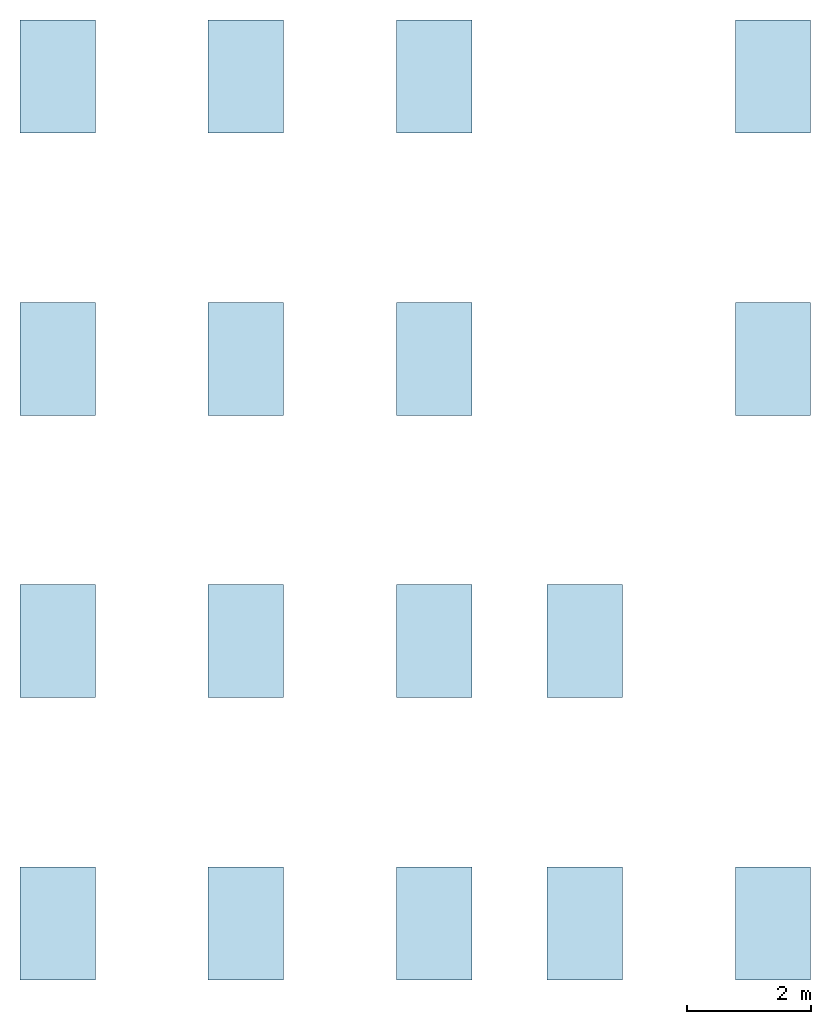
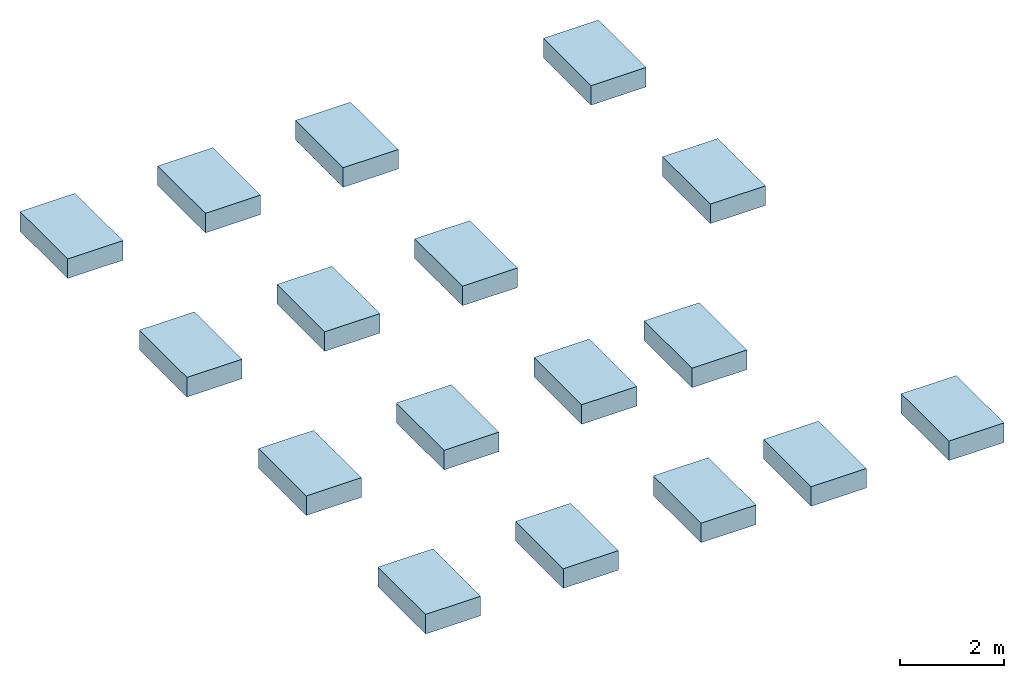
# One storey: 17 slabs.
"""IFC2X3 building model written with IfcOpenShell, lengths in feet."""

from ifc_helpers import new_model, entity, si_unit, converted_unit, derived_unit, direction, frame, frame_2d, origin, origin_2d_with_axis, place, context, subcontext, project, spatial, rectangle, extrude, material, type_object, element, save


model = new_model("IFC2X3")

# Units and contexts
model_context = context("Model", 3, precision=0.0001, world=origin(), true_north=direction((6.123031769111886e-17, 1.0)))
body_context = subcontext(model_context, "Body", "Model", "MODEL_VIEW")
ifc_project = project(units=[converted_unit("LENGTHUNIT", "FOOT", entity("IfcLengthMeasure", 0.3048), si_unit("LENGTHUNIT", "METRE"), dimensions=[1, 0, 0, 0, 0, 0, 0]), converted_unit("AREAUNIT", "SQUARE FOOT", entity("IfcAreaMeasure", 0.09290304), si_unit("AREAUNIT", "SQUARE_METRE"), dimensions=[2, 0, 0, 0, 0, 0, 0]), converted_unit("VOLUMEUNIT", "CUBIC FOOT", entity("IfcVolumeMeasure", 0.028316846592000004), si_unit("VOLUMEUNIT", "CUBIC_METRE"), dimensions=[3, 0, 0, 0, 0, 0, 0]), converted_unit("PLANEANGLEUNIT", "DEGREE", entity("IfcPlaneAngleMeasure", 0.017453292519943278), si_unit("PLANEANGLEUNIT", "RADIAN"), dimensions=[0, 0, 0, 0, 0, 0, 0]), si_unit("MASSUNIT", "GRAM", prefix="KILO"), derived_unit("MASSDENSITYUNIT", [(si_unit("MASSUNIT", "GRAM", prefix="KILO"), 1), (si_unit("LENGTHUNIT", "METRE"), -3)]), derived_unit("IONCONCENTRATIONUNIT", [(si_unit("MASSUNIT", "GRAM", prefix="KILO"), 1), (si_unit("LENGTHUNIT", "METRE"), -3)]), derived_unit("MOMENTOFINERTIAUNIT", [(si_unit("LENGTHUNIT", "METRE"), 4)]), si_unit("TIMEUNIT", "SECOND"), si_unit("FREQUENCYUNIT", "HERTZ"), si_unit("THERMODYNAMICTEMPERATUREUNIT", "DEGREE_CELSIUS"), derived_unit("THERMALTRANSMITTANCEUNIT", [(si_unit("MASSUNIT", "GRAM", prefix="KILO"), 1), (si_unit("THERMODYNAMICTEMPERATUREUNIT", "KELVIN"), -1), (si_unit("TIMEUNIT", "SECOND"), -3)]), derived_unit("THERMALCONDUCTANCEUNIT", [(si_unit("MASSUNIT", "GRAM", prefix="KILO"), 1), (si_unit("THERMODYNAMICTEMPERATUREUNIT", "KELVIN"), -1), (si_unit("TIMEUNIT", "SECOND"), -3), (si_unit("LENGTHUNIT", "METRE"), 1)]), derived_unit("VOLUMETRICFLOWRATEUNIT", [(si_unit("LENGTHUNIT", "METRE"), 3), (si_unit("TIMEUNIT", "SECOND"), -1)]), derived_unit("MASSFLOWRATEUNIT", [(si_unit("MASSUNIT", "GRAM", prefix="KILO"), 1), (si_unit("TIMEUNIT", "SECOND"), -1)]), derived_unit("ROTATIONALFREQUENCYUNIT", [(si_unit("TIMEUNIT", "SECOND"), -1)]), si_unit("ELECTRICCURRENTUNIT", "AMPERE"), si_unit("ELECTRICVOLTAGEUNIT", "VOLT"), si_unit("POWERUNIT", "WATT"), converted_unit("FORCEUNIT", "KIP", entity("IfcForceMeasure", 2.088543423315013e-05), si_unit("FORCEUNIT", "NEWTON"), dimensions=[1, 1, -2, 0, 0, 0, 0]), si_unit("ILLUMINANCEUNIT", "LUX"), si_unit("LUMINOUSFLUXUNIT", "LUMEN"), si_unit("LUMINOUSINTENSITYUNIT", "CANDELA"), si_unit("ENERGYUNIT", "JOULE"), derived_unit("USERDEFINED", [(si_unit("MASSUNIT", "GRAM", prefix="KILO"), -1), (si_unit("LENGTHUNIT", "METRE"), -2), (si_unit("TIMEUNIT", "SECOND"), 3), (si_unit("LUMINOUSFLUXUNIT", "LUMEN"), 1)]), derived_unit("USERDEFINED", [(si_unit("MASSUNIT", "GRAM", prefix="KILO"), 1), (si_unit("TIMEUNIT", "SECOND"), -3), (si_unit("LENGTHUNIT", "METRE"), 3), (si_unit("ELECTRICCURRENTUNIT", "AMPERE"), -2)]), derived_unit("SOUNDPOWERUNIT", [(si_unit("MASSUNIT", "GRAM", prefix="KILO"), 1), (si_unit("TIMEUNIT", "SECOND"), -3), (si_unit("LENGTHUNIT", "METRE"), 2)]), derived_unit("SOUNDPRESSUREUNIT", [(si_unit("MASSUNIT", "GRAM", prefix="KILO"), 1), (si_unit("LENGTHUNIT", "METRE"), -1), (si_unit("TIMEUNIT", "SECOND"), -2)]), derived_unit("LINEARVELOCITYUNIT", [(si_unit("LENGTHUNIT", "METRE"), 1), (si_unit("TIMEUNIT", "SECOND"), -1)]), si_unit("PRESSUREUNIT", "PASCAL"), derived_unit("USERDEFINED", [(si_unit("MASSUNIT", "GRAM", prefix="KILO"), 1), (si_unit("LENGTHUNIT", "METRE"), -2), (si_unit("TIMEUNIT", "SECOND"), -2)]), derived_unit("LINEARFORCEUNIT", [(si_unit("MASSUNIT", "GRAM", prefix="KILO"), 1), (si_unit("TIMEUNIT", "SECOND"), -2)]), derived_unit("PLANARFORCEUNIT", [(si_unit("MASSUNIT", "GRAM", prefix="KILO"), 1), (si_unit("LENGTHUNIT", "METRE"), -1), (si_unit("TIMEUNIT", "SECOND"), -2)]), derived_unit("SPECIFICHEATCAPACITYUNIT", [(si_unit("THERMODYNAMICTEMPERATUREUNIT", "KELVIN"), -1), (si_unit("LENGTHUNIT", "METRE"), 2), (si_unit("TIMEUNIT", "SECOND"), -2)]), derived_unit("HEATFLUXDENSITYUNIT", [(si_unit("MASSUNIT", "GRAM", prefix="KILO"), 1), (si_unit("TIMEUNIT", "SECOND"), -3)]), derived_unit("HEATINGVALUEUNIT", [(si_unit("LENGTHUNIT", "METRE"), 2), (si_unit("TIMEUNIT", "SECOND"), -2)]), derived_unit("VAPORPERMEABILITYUNIT", [(si_unit("LENGTHUNIT", "METRE"), -1), (si_unit("TIMEUNIT", "SECOND"), 1)]), derived_unit("DYNAMICVISCOSITYUNIT", [(si_unit("MASSUNIT", "GRAM", prefix="KILO"), 1), (si_unit("TIMEUNIT", "SECOND"), -1), (si_unit("LENGTHUNIT", "METRE"), -1)]), derived_unit("THERMALEXPANSIONCOEFFICIENTUNIT", [(si_unit("THERMODYNAMICTEMPERATUREUNIT", "KELVIN"), -1)]), derived_unit("MODULUSOFELASTICITYUNIT", [(si_unit("MASSUNIT", "GRAM", prefix="KILO"), 1), (si_unit("LENGTHUNIT", "METRE"), -1), (si_unit("TIMEUNIT", "SECOND"), -2)]), derived_unit("ISOTHERMALMOISTURECAPACITYUNIT", [(si_unit("LENGTHUNIT", "METRE"), 3), (si_unit("MASSUNIT", "GRAM", prefix="KILO"), -1)]), derived_unit("MOISTUREDIFFUSIVITYUNIT", [(si_unit("TIMEUNIT", "SECOND"), -1), (si_unit("LENGTHUNIT", "METRE"), 2)]), derived_unit("MASSPERLENGTHUNIT", [(si_unit("MASSUNIT", "GRAM", prefix="KILO"), 1), (si_unit("LENGTHUNIT", "METRE"), -1)]), derived_unit("THERMALRESISTANCEUNIT", [(si_unit("MASSUNIT", "GRAM", prefix="KILO"), -1), (si_unit("TIMEUNIT", "SECOND"), 3), (si_unit("THERMODYNAMICTEMPERATUREUNIT", "KELVIN"), 1)]), derived_unit("ACCELERATIONUNIT", [(si_unit("LENGTHUNIT", "METRE"), 1), (si_unit("TIMEUNIT", "SECOND"), -2)]), derived_unit("ANGULARVELOCITYUNIT", [(si_unit("TIMEUNIT", "SECOND"), -1), (si_unit("PLANEANGLEUNIT", "RADIAN"), 1)]), derived_unit("LINEARSTIFFNESSUNIT", [(si_unit("MASSUNIT", "GRAM", prefix="KILO"), 1), (si_unit("TIMEUNIT", "SECOND"), -2)]), derived_unit("WARPINGCONSTANTUNIT", [(si_unit("LENGTHUNIT", "METRE"), 6)]), derived_unit("LINEARMOMENTUNIT", [(si_unit("MASSUNIT", "GRAM", prefix="KILO"), 1), (si_unit("LENGTHUNIT", "METRE"), 1), (si_unit("TIMEUNIT", "SECOND"), -2)]), derived_unit("TORQUEUNIT", [(si_unit("MASSUNIT", "GRAM", prefix="KILO"), 1), (si_unit("LENGTHUNIT", "METRE"), 2), (si_unit("TIMEUNIT", "SECOND"), -2)])], contexts=[model_context])

# Site, building, storey
site_placement = place(None, origin())
site = spatial("IfcSite", under=ifc_project, at=site_placement, CompositionType="ELEMENT")
building_placement = place(site_placement, origin())
building = spatial("IfcBuilding", under=site, at=building_placement, CompositionType="ELEMENT")
storey_placement = place(building_placement, frame((0.0, 0.0, -1.5)))
storey = spatial("IfcBuildingStorey", under=building, at=storey_placement, CompositionType="ELEMENT", Elevation=-1.5)

# Slabs
ifc_material = material(Name="Concrete, Cast-in-Place gray")
slab_type = type_object("IfcSlabType", PredefinedType="BASESLAB", material=ifc_material)
slab_1_placement = place(storey_placement, origin())
element("IfcSlab", 1, at=slab_1_placement, inside=storey, type_object=slab_type, PredefinedType="BASESLAB", context=body_context, shape_type="SweptSolid", body=[
    extrude(rectangle(XDim=3.9999999999999982, YDim=6.0, at=origin_2d_with_axis()), frame((9.874478019162163, -49.84124484724893, -1.5), z_axis=(0.0, 0.0, 1.0), x_axis=(-1.0, 0.0, 0.0)), (0.0, 0.0, 1.0), 1.5),
])
slab_2_placement = place(storey_placement, origin())
element("IfcSlab", 2, at=slab_2_placement, inside=storey, type_object=slab_type, PredefinedType="BASESLAB", context=body_context, shape_type="SweptSolid", body=[
    extrude(rectangle(XDim=4.0, YDim=6.0, at=frame_2d((-1.7763568394002505e-15, -7.105427357601002e-15), x_axis=(1.0, 0.0))), frame((29.874478019162154, -49.841244847249, -1.5), z_axis=(0.0, 0.0, 1.0), x_axis=(-1.0, 0.0, 0.0)), (0.0, 0.0, 1.0), 1.5),
])
slab_3_placement = place(storey_placement, origin())
element("IfcSlab", 3, at=slab_3_placement, inside=storey, type_object=slab_type, PredefinedType="BASESLAB", context=body_context, shape_type="SweptSolid", body=[
    extrude(rectangle(XDim=4.0, YDim=6.0, at=frame_2d((3.552713678800501e-15, 7.105427357601002e-15), x_axis=(1.0, 0.0))), frame((37.87447801916216, -49.841244847249015, -1.5), z_axis=(0.0, 0.0, 1.0), x_axis=(-1.0, 0.0, 0.0)), (0.0, 0.0, 1.0), 1.5),
])
slab_4_placement = place(storey_placement, origin())
element("IfcSlab", 4, at=slab_4_placement, inside=storey, type_object=slab_type, PredefinedType="BASESLAB", context=body_context, shape_type="SweptSolid", body=[
    extrude(rectangle(XDim=4.0, YDim=6.0, at=frame_2d((3.552713678800501e-15, 0.0), x_axis=(1.0, 0.0))), frame((47.87447801916217, -49.84124484724906, -1.5), z_axis=(0.0, 0.0, 1.0), x_axis=(-1.0, 0.0, 0.0)), (0.0, 0.0, 1.0), 1.5),
])
slab_5_placement = place(storey_placement, origin())
element("IfcSlab", 5, at=slab_5_placement, inside=storey, type_object=slab_type, PredefinedType="BASESLAB", context=body_context, shape_type="SweptSolid", body=[
    extrude(rectangle(XDim=4.0, YDim=6.0, at=frame_2d((1.7763568394002505e-15, 7.105427357601002e-15), x_axis=(1.0, 0.0))), frame((19.87447801916216, -49.84124484724896, -1.5), z_axis=(0.0, 0.0, 1.0), x_axis=(-1.0, 0.0, 0.0)), (0.0, 0.0, 1.0), 1.5),
])
slab_6_placement = place(storey_placement, origin())
element("IfcSlab", 6, at=slab_6_placement, inside=storey, type_object=slab_type, PredefinedType="BASESLAB", context=body_context, shape_type="SweptSolid", body=[
    extrude(rectangle(XDim=3.9999999999999982, YDim=6.0, at=origin_2d_with_axis()), frame((9.874478019162188, -34.84124484724893, -1.5), z_axis=(0.0, 0.0, 1.0), x_axis=(-1.0, 0.0, 0.0)), (0.0, 0.0, 1.0), 1.5),
])
slab_7_placement = place(storey_placement, origin())
element("IfcSlab", 7, at=slab_7_placement, inside=storey, type_object=slab_type, PredefinedType="BASESLAB", context=body_context, shape_type="SweptSolid", body=[
    extrude(rectangle(XDim=4.0, YDim=6.0, at=frame_2d((-1.7763568394002505e-15, 0.0), x_axis=(1.0, 0.0))), frame((29.87447801916219, -34.841244847248994, -1.5), z_axis=(0.0, 0.0, 1.0), x_axis=(-1.0, 0.0, 0.0)), (0.0, 0.0, 1.0), 1.5),
])
slab_8_placement = place(storey_placement, origin())
element("IfcSlab", 8, at=slab_8_placement, inside=storey, type_object=slab_type, PredefinedType="BASESLAB", context=body_context, shape_type="SweptSolid", body=[
    extrude(rectangle(XDim=4.0, YDim=6.0, at=frame_2d((3.552713678800501e-15, 0.0), x_axis=(1.0, 0.0))), frame((37.87447801916219, -34.84124484724902, -1.5), z_axis=(0.0, 0.0, 1.0), x_axis=(-1.0, 0.0, 0.0)), (0.0, 0.0, 1.0), 1.5),
])
slab_9_placement = place(storey_placement, origin())
element("IfcSlab", 9, at=slab_9_placement, inside=storey, type_object=slab_type, PredefinedType="BASESLAB", context=body_context, shape_type="SweptSolid", body=[
    extrude(rectangle(XDim=4.0, YDim=6.0, at=frame_2d((-1.7763568394002505e-15, 0.0), x_axis=(1.0, 0.0))), frame((19.874478019162183, -34.841244847248966, -1.5), z_axis=(0.0, 0.0, 1.0), x_axis=(-1.0, 0.0, 0.0)), (0.0, 0.0, 1.0), 1.5),
])
slab_10_placement = place(storey_placement, origin())
element("IfcSlab", 10, at=slab_10_placement, inside=storey, type_object=slab_type, PredefinedType="BASESLAB", context=body_context, shape_type="SweptSolid", body=[
    extrude(rectangle(XDim=3.9999999999999982, YDim=6.0, at=origin_2d_with_axis()), frame((9.874478019162213, -19.84124484724893, -1.5), z_axis=(0.0, 0.0, 1.0), x_axis=(-1.0, 0.0, 0.0)), (0.0, 0.0, 1.0), 1.5),
])
slab_11_placement = place(storey_placement, origin())
element("IfcSlab", 11, at=slab_11_placement, inside=storey, type_object=slab_type, PredefinedType="BASESLAB", context=body_context, shape_type="SweptSolid", body=[
    extrude(rectangle(XDim=4.0, YDim=6.0, at=frame_2d((-1.7763568394002505e-15, 0.0), x_axis=(1.0, 0.0))), frame((29.87447801916221, -19.841244847248994, -1.5), z_axis=(0.0, 0.0, 1.0), x_axis=(-1.0, 0.0, 0.0)), (0.0, 0.0, 1.0), 1.5),
])
slab_12_placement = place(storey_placement, origin())
element("IfcSlab", 12, at=slab_12_placement, inside=storey, type_object=slab_type, PredefinedType="BASESLAB", context=body_context, shape_type="SweptSolid", body=[
    extrude(rectangle(XDim=4.0, YDim=6.0, at=frame_2d((3.552713678800501e-15, 0.0), x_axis=(1.0, 0.0))), frame((47.87447801916221, -19.841244847249058, -1.5), z_axis=(0.0, 0.0, 1.0), x_axis=(-1.0, 0.0, 0.0)), (0.0, 0.0, 1.0), 1.5),
])
slab_13_placement = place(storey_placement, origin())
element("IfcSlab", 13, at=slab_13_placement, inside=storey, type_object=slab_type, PredefinedType="BASESLAB", context=body_context, shape_type="SweptSolid", body=[
    extrude(rectangle(XDim=4.0, YDim=6.0, at=frame_2d((-1.7763568394002505e-15, 0.0), x_axis=(1.0, 0.0))), frame((19.874478019162204, -19.841244847248966, -1.5), z_axis=(0.0, 0.0, 1.0), x_axis=(-1.0, 0.0, 0.0)), (0.0, 0.0, 1.0), 1.5),
])
slab_14_placement = place(storey_placement, origin())
element("IfcSlab", 14, at=slab_14_placement, inside=storey, type_object=slab_type, PredefinedType="BASESLAB", context=body_context, shape_type="SweptSolid", body=[
    extrude(rectangle(XDim=4.0, YDim=6.0, at=frame_2d((-9.992007221626409e-16, -4.440892098500626e-16), x_axis=(1.0, 0.0))), frame((9.874478019162236, -4.841244847248884, -1.5), z_axis=(0.0, 0.0, 1.0), x_axis=(-1.0, 0.0, 0.0)), (0.0, 0.0, 1.0), 1.5),
])
slab_15_placement = place(storey_placement, origin())
element("IfcSlab", 15, at=slab_15_placement, inside=storey, type_object=slab_type, PredefinedType="BASESLAB", context=body_context, shape_type="SweptSolid", body=[
    extrude(rectangle(XDim=4.0, YDim=6.0, at=frame_2d((1.887379141862766e-15, -4.440892098500626e-16), x_axis=(1.0, 0.0))), frame((29.874478019162236, -4.841244847248948, -1.5), z_axis=(0.0, 0.0, 1.0), x_axis=(-1.0, 0.0, 0.0)), (0.0, 0.0, 1.0), 1.5),
])
slab_16_placement = place(storey_placement, origin())
element("IfcSlab", 16, at=slab_16_placement, inside=storey, type_object=slab_type, PredefinedType="BASESLAB", context=body_context, shape_type="SweptSolid", body=[
    extrude(rectangle(XDim=4.0, YDim=6.0, at=frame_2d((3.6637359812630166e-15, 4.440892098500626e-16), x_axis=(1.0, 0.0))), frame((47.87447801916224, -4.841244847249005, -1.5), z_axis=(0.0, 0.0, 1.0), x_axis=(-1.0, 0.0, 0.0)), (0.0, 0.0, 1.0), 1.5),
])
slab_17_placement = place(storey_placement, origin())
element("IfcSlab", 17, at=slab_17_placement, inside=storey, type_object=slab_type, PredefinedType="BASESLAB", context=body_context, shape_type="SweptSolid", body=[
    extrude(rectangle(XDim=4.0, YDim=6.0, at=frame_2d((1.887379141862766e-15, 4.440892098500626e-16), x_axis=(1.0, 0.0))), frame((19.874478019162233, -4.841244847248914, -1.5), z_axis=(0.0, 0.0, 1.0), x_axis=(-1.0, 0.0, 0.0)), (0.0, 0.0, 1.0), 1.5),
])

save(model, "model.ifc")
